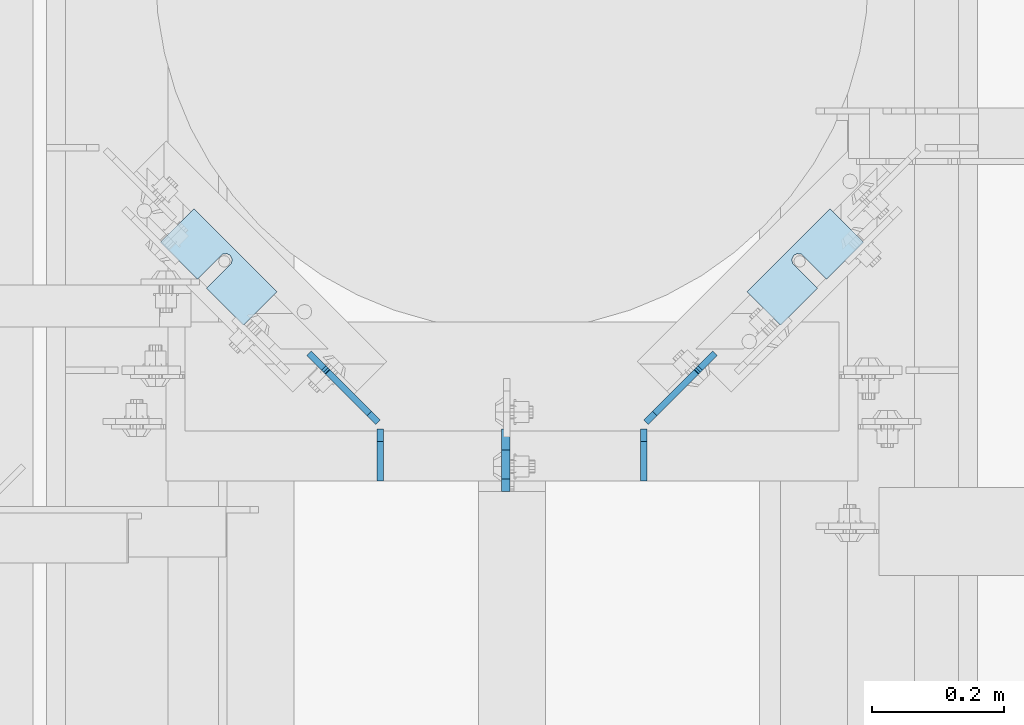
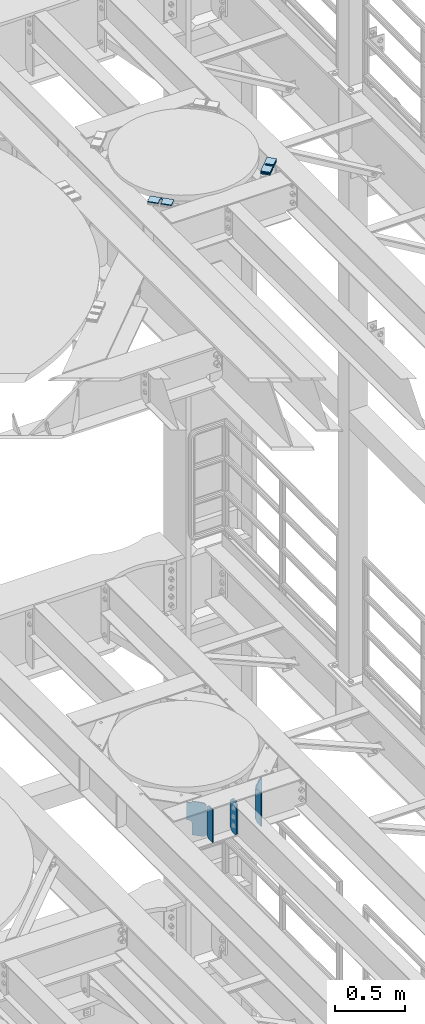
# One storey, part 1791 of 1876: 14 plates, 10 elements without a shape of their own.
"""IFC2X3 building model written with IfcOpenShell, lengths in millimetres."""

from ifc_helpers import new_model, si_unit, frame, origin_with_axes, place, context, subcontext, project, spatial, faceted_brep, material, type_object, element, aggregate, save


model = new_model("IFC2X3")

# Units and contexts
model_context = context("Model", 3, precision=1e-05, world=origin_with_axes())
body_context = subcontext(model_context, "Body", "Model", "MODEL_VIEW")
ifc_project = project(units=[si_unit("LENGTHUNIT", "METRE", prefix="MILLI"), si_unit("AREAUNIT", "SQUARE_METRE"), si_unit("VOLUMEUNIT", "CUBIC_METRE"), si_unit("MASSUNIT", "GRAM", prefix="KILO"), si_unit("TIMEUNIT", "SECOND"), si_unit("PLANEANGLEUNIT", "RADIAN"), si_unit("SOLIDANGLEUNIT", "STERADIAN"), si_unit("THERMODYNAMICTEMPERATUREUNIT", "DEGREE_CELSIUS"), si_unit("LUMINOUSINTENSITYUNIT", "LUMEN")], contexts=[model_context])

# Site, building, storey
site_placement = place(None, origin_with_axes())
site = spatial("IfcSite", under=ifc_project, at=site_placement, CompositionType="ELEMENT")
building_placement = place(site_placement, origin_with_axes())
building = spatial("IfcBuilding", under=site, at=building_placement, Name="Undefined", CompositionType="ELEMENT")
storey_placement = place(building_placement, origin_with_axes())
storey = spatial("IfcBuildingStorey", under=building, at=storey_placement, Name="Undefined", CompositionType="ELEMENT", Elevation=0.0)

# Assembly, plates
assembly_1_placement = place(storey_placement, origin_with_axes())
assembly_1 = element("IfcElementAssembly", 1, at=assembly_1_placement, inside=storey, Name="BEAM", AssemblyPlace="NOTDEFINED", PredefinedType="RIGID_FRAME")
ifc_material = material(Name="STEEL/A36")
plate_type_1 = type_object("IfcPlateType", PredefinedType="NOTDEFINED")
plate_1_placement = place(assembly_1_placement, frame((6099.17499990463, 10791.825, 7853.3625), z_axis=(0.0, 0.0, 1.0), x_axis=(0.0, -1.0, 0.0)))
plate_1 = element("IfcPlate", 2, at=plate_1_placement, type_object=plate_type_1, material=ifc_material, Name="PLATE", context=body_context, shape_type="Brep", body=[
    faceted_brep([(0.0, -6.34999999999991, 31.75), (0.0, -6.35000000000036, 258.762512207031), (0.0, 6.35000000000036, 258.762512207031), (0.0, 6.34999999999991, 31.75), (31.75, -6.35000000000036, 290.512512207031), (31.75, 6.35000000000036, 290.512512207031), (76.2000007629395, -6.35000000000036, 290.512512207031), (76.2000007629395, 6.35000000000036, 290.512512207031), (95.25, -6.35000000000036, 271.462512969971), (95.25, 6.35000000000036, 271.462512969971), (95.25, -6.35000000000036, 19.0499992370605), (95.25, 6.35000000000036, 19.0499992370605), (76.2000007629395, -6.35000000000036, 0.0), (76.2000007629395, 6.35000000000036, 0.0), (31.75, -6.34999999999991, 0.0), (31.75, 6.34999999999991, 0.0)], [[[0, 1, 2, 3]], [[1, 4, 5, 2]], [[4, 6, 7, 5]], [[6, 8, 9, 7]], [[8, 10, 11, 9]], [[10, 12, 13, 11]], [[12, 14, 15, 13]], [[14, 0, 3, 15]], [[5, 7, 9, 11, 13, 15, 3, 2]], [[14, 12, 10, 8, 6, 4, 1, 0]]]),
])
plate_type_2 = type_object("IfcPlateType", PredefinedType="NOTDEFINED")
plate_2_placement = place(assembly_1_placement, frame((6308.27321782047, 10791.825, 7853.3625), z_axis=(0.0, 0.0, 1.0), x_axis=(0.0, -1.0, 0.0)))
plate_2 = element("IfcPlate", 3, at=plate_2_placement, type_object=plate_type_2, material=ifc_material, Name="PLATE", context=body_context, shape_type="Brep", body=[
    faceted_brep([(0.0, -4.76249999999982, 19.0499992370605), (0.0, -4.76250000000073, 269.874988555908), (0.0, 4.76250000000073, 269.874988555908), (0.0, 4.76249999999982, 19.0499992370605), (19.0499992370605, -4.76250000000073, 288.924987792969), (19.0499992370605, 4.76250000000073, 288.924987792969), (79.375, -4.76250000000073, 288.924987792969), (79.375, 4.76250000000073, 288.924987792969), (79.375, -4.76250000000073, 0.0), (79.375, 4.76250000000073, 0.0), (19.0499992370605, -4.76249999999982, 0.0), (19.0499992370605, 4.76249999999982, 0.0)], [[[0, 1, 2, 3]], [[1, 4, 5, 2]], [[4, 6, 7, 5]], [[6, 8, 9, 7]], [[8, 10, 11, 9]], [[10, 0, 3, 11]], [[5, 7, 9, 11, 3, 2]], [[10, 8, 6, 4, 1, 0]]]),
])
plate_3_placement = place(assembly_1_placement, frame((5909.12678217874, 10791.825, 7853.36250000001), z_axis=(0.0, 0.0, 1.0), x_axis=(0.0, -1.0, 0.0)))
plate_3 = element("IfcPlate", 4, at=plate_3_placement, type_object=plate_type_2, material=ifc_material, Name="PLATE", context=body_context, shape_type="Brep", body=[
    faceted_brep([(0.0, -4.76249999999982, 19.0499992370605), (0.0, -4.76250000000073, 269.874988555908), (0.0, 4.76250000000073, 269.874988555908), (0.0, 4.76249999999982, 19.0499992370605), (19.0499992370605, -4.76250000000073, 288.924987792969), (19.0499992370605, 4.76250000000073, 288.924987792969), (79.375, -4.76250000000073, 288.924987792969), (79.375, 4.76250000000073, 288.924987792969), (79.375, -4.76250000000073, 0.0), (79.375, 4.76250000000073, 0.0), (19.0499992370605, -4.76249999999982, 0.0), (19.0499992370605, 4.76249999999982, 0.0)], [[[0, 1, 2, 3]], [[1, 4, 5, 2]], [[4, 6, 7, 5]], [[6, 8, 9, 7]], [[8, 10, 11, 9]], [[10, 0, 3, 11]], [[5, 7, 9, 11, 3, 2]], [[10, 8, 6, 4, 1, 0]]]),
])
plate_type_3 = type_object("IfcPlateType", PredefinedType="NOTDEFINED")
plate_4_placement = place(assembly_1_placement, frame((6311.64310582087, 10801.5430549594, 7870.825), z_axis=(0.500120633849922, 0.499879336849994, 0.707106781319457), x_axis=(0.500120634037941, 0.499879337037901, -0.707106781053638)))
plate_4 = element("IfcPlate", 5, at=plate_4_placement, type_object=plate_type_3, material=ifc_material, Name="PLATE", context=body_context, shape_type="Brep", body=[
    faceted_brep([(0.0, -4.76249999999982, 0.0), (-179.605117797772, -4.76249999999527, 179.605117797992), (-179.605117797772, 4.76250000000437, 179.605117797993), (0.0, 4.76249999999982, 0.0), (-179.605117797761, -4.76249999999891, 206.545883178862), (-179.605117797761, 4.76250000000255, 206.545883178861), (-117.050567626848, -4.76250000000618, 269.100433349755), (-117.050567626846, 4.76249999999163, 269.100433349757), (-115.928035765697, -4.762500000008, 267.977902251546), (-115.928035765697, 4.76249999999163, 267.977902251546), (-111.292837558296, -4.762500000008, 264.880763707778), (-111.292837558296, 4.76249999998981, 264.880763707779), (-105.825249325861, -4.76250000000982, 263.793193709241), (-105.825249325861, 4.76249999998981, 263.793193709242), (-100.357661316782, -4.76250000001164, 264.880764830663), (-100.357661316781, 4.76249999998981, 264.880764830663), (-95.7224637454437, -4.76250000001346, 267.977904326366), (-95.7224637454419, 4.76249999998618, 267.977904326366), (-77.4542999266487, -4.76250000001892, 286.246063232559), (-77.4542999266469, 4.76249999998254, 286.246063232559), (30.3087749481838, -4.76250000002619, 178.483001709037), (30.3087749481838, 4.76249999997526, 178.483001709038), (14.2856747239093, -4.76250000002074, 162.459897647188), (14.2856747239111, 4.7624999999789, 162.459897647189), (10.5002814525251, -4.76250000001892, 156.794654920826), (10.5002814525251, 4.76249999998072, 156.794654920827), (9.17102848077957, -4.76250000001892, 150.112045856642), (9.17102848077957, 4.76249999998072, 150.112045856642), (10.5002825029787, -4.76250000002074, 143.429437001402), (10.5002825029787, 4.76249999998072, 143.429437001403), (14.2856766648929, -4.76250000001892, 137.764194870075), (14.2856766648929, 4.76249999998072, 137.764194870074), (89.4953231811687, -4.76250000002437, 62.5545539855825), (89.4953231811687, 4.76249999997708, 62.5545539855834), (26.9407691955548, -4.76250000000618, -2.22826201934367e-11), (26.9407691955548, 4.76249999999345, -2.22826201934367e-11)], [[[0, 1, 2, 3]], [[1, 4, 5, 2]], [[4, 6, 7, 5]], [[6, 8, 9, 7]], [[8, 10, 11, 9]], [[10, 12, 13, 11]], [[12, 14, 15, 13]], [[14, 16, 17, 15]], [[16, 18, 19, 17]], [[18, 20, 21, 19]], [[20, 22, 23, 21]], [[22, 24, 25, 23]], [[24, 26, 27, 25]], [[26, 28, 29, 27]], [[28, 30, 31, 29]], [[30, 32, 33, 31]], [[32, 34, 35, 33]], [[34, 0, 3, 35]], [[5, 7, 9, 11, 13, 15, 17, 19, 21, 23, 25, 27, 29, 31, 33, 35, 3, 2]], [[34, 32, 30, 28, 26, 24, 22, 20, 18, 16, 14, 12, 10, 8, 6, 4, 1, 0]]]),
])
plate_5_placement = place(assembly_1_placement, frame((5905.75689417819, 10801.5430549604, 7870.825), z_axis=(-0.50012063384991, 0.499879336849982, 0.707106781319474), x_axis=(-0.500120634037935, 0.499879337037929, -0.707106781053622)))
plate_5 = element("IfcPlate", 6, at=plate_5_placement, type_object=plate_type_3, material=ifc_material, Name="PLATE", context=body_context, shape_type="Brep", body=[
    faceted_brep([(0.0, -4.76249999999982, 0.0), (-179.605117797772, -4.76249999999527, 179.605117797992), (-179.605117797772, 4.76250000000437, 179.605117797993), (0.0, 4.76249999999982, 0.0), (-179.605117797761, -4.76249999999891, 206.545883178862), (-179.605117797761, 4.76250000000255, 206.545883178861), (-117.050567626848, -4.76250000000618, 269.100433349755), (-117.050567626846, 4.76249999999163, 269.100433349757), (-115.928035765697, -4.762500000008, 267.977902251546), (-115.928035765697, 4.76249999999163, 267.977902251546), (-111.292837558296, -4.762500000008, 264.880763707778), (-111.292837558296, 4.76249999998981, 264.880763707779), (-105.825249325861, -4.76250000000982, 263.793193709241), (-105.825249325861, 4.76249999998981, 263.793193709242), (-100.357661316782, -4.76250000001164, 264.880764830663), (-100.357661316781, 4.76249999998981, 264.880764830663), (-95.7224637454437, -4.76250000001346, 267.977904326366), (-95.7224637454419, 4.76249999998618, 267.977904326366), (-77.4542999266487, -4.76250000001892, 286.246063232559), (-77.4542999266469, 4.76249999998254, 286.246063232559), (30.3087749481838, -4.76250000002619, 178.483001709037), (30.3087749481838, 4.76249999997526, 178.483001709038), (14.2856747239093, -4.76250000002074, 162.459897647188), (14.2856747239111, 4.7624999999789, 162.459897647189), (10.5002814525251, -4.76250000001892, 156.794654920826), (10.5002814525251, 4.76249999998072, 156.794654920827), (9.17102848077957, -4.76250000001892, 150.112045856642), (9.17102848077957, 4.76249999998072, 150.112045856642), (10.5002825029787, -4.76250000002074, 143.429437001402), (10.5002825029787, 4.76249999998072, 143.429437001403), (14.2856766648929, -4.76250000001892, 137.764194870075), (14.2856766648929, 4.76249999998072, 137.764194870074), (89.4953231811687, -4.76250000002437, 62.5545539855825), (89.4953231811687, 4.76249999997708, 62.5545539855834), (26.9407691955548, -4.76250000000618, -2.22826201934367e-11), (26.9407691955548, 4.76249999999345, -2.22826201934367e-11)], [[[0, 1, 2, 3]], [[1, 4, 5, 2]], [[4, 6, 7, 5]], [[6, 8, 9, 7]], [[8, 10, 11, 9]], [[10, 12, 13, 11]], [[12, 14, 15, 13]], [[14, 16, 17, 15]], [[16, 18, 19, 17]], [[18, 20, 21, 19]], [[20, 22, 23, 21]], [[22, 24, 25, 23]], [[24, 26, 27, 25]], [[26, 28, 29, 27]], [[28, 30, 31, 29]], [[30, 32, 33, 31]], [[32, 34, 35, 33]], [[34, 0, 3, 35]], [[5, 7, 9, 11, 13, 15, 17, 19, 21, 23, 25, 27, 29, 31, 33, 35, 3, 2]], [[34, 32, 30, 28, 26, 24, 22, 20, 18, 16, 14, 12, 10, 8, 6, 4, 1, 0]]]),
])
aggregate(assembly_1, [plate_1, plate_2, plate_4, plate_3, plate_5])

# Assembly, plate
assembly_2_placement = place(storey_placement, origin_with_axes())
assembly_2 = element("IfcElementAssembly", 7, at=assembly_2_placement, inside=storey, Name="SHIM PLATE", AssemblyPlace="NOTDEFINED", PredefinedType="RIGID_FRAME")
plate_type_4 = type_object("IfcPlateType", PredefinedType="NOTDEFINED")
plate_6_placement = place(assembly_2_placement, frame((6464.5722604217, 10999.2121093142, 13335.7925), z_axis=(0.707095463095971, 0.707118099095967, 0.0), x_axis=(0.707118099095967, -0.707095463095971, 0.0)))
plate_6 = element("IfcPlate", 8, at=plate_6_placement, type_object=plate_type_4, material=ifc_material, Name="SHIM PLATE", context=body_context, shape_type="Brep", body=[
    faceted_brep([(71.4045474198501, -0.793499999999767, 79.3704623494177), (71.4045474198501, 0.793499999999767, 79.3704623494177), (23.7781246776649, 0.793499999999767, 79.3704112277637), (23.7781246776649, -0.793499999999767, 79.3704112277637), (17.7435939503794, 0.793499999999767, 79.5232321855556), (17.7435939503794, -0.793499999999767, 79.5232321855556), (12.9144746082529, 0.793499999999767, 83.1451821745986), (12.9144746082529, -0.793499999999767, 83.1451821745986), (11.0782662795154, 0.793499999999767, 88.8955955786168), (11.0782662795154, -0.793499999999767, 88.8955955786168), (12.9146418967375, 0.793499999999767, 94.6459555617994), (12.9146418967375, -0.793499999999767, 94.6459555617994), (17.7438666054786, 0.793499999999767, 98.267765062069), (17.7438666054786, -0.793499999999767, 98.267765062069), (23.7784017760332, 0.793499999999767, 98.4204104651026), (23.7784017760332, -0.793499999999767, 98.4204104651026), (71.4046756165244, -0.793499999999767, 98.4204615866147), (71.4045269830331, 0.793499999999767, 98.4204615864555), (71.4046325683794, -0.793499999999767, -1.18234311230481e-11), (9.09494701772928e-13, -0.793499999999767, 0.0), (9.09494701772928e-13, 0.793499999999767, 0.0), (71.4046325683794, 0.793499999999767, -1.18234311230481e-11), (0.00273432340327417, -0.793499999999767, 177.792755126891), (0.00273432340327417, 0.793499999999767, 177.792755126891), (71.4044418336562, -0.793499999999767, 177.791717529223), (71.4044418336562, 0.793499999999767, 177.791717529223)], [[[0, 1, 2, 3]], [[3, 2, 4, 5]], [[5, 4, 6, 7]], [[7, 6, 8, 9]], [[9, 8, 10, 11]], [[11, 10, 12, 13]], [[13, 12, 14, 15]], [[16, 15, 14, 17]], [[18, 19, 20, 21]], [[19, 22, 23, 20]], [[22, 24, 25, 23]], [[25, 24, 16, 17]], [[12, 10, 8, 6, 4, 2, 1, 21, 20, 23, 25, 17, 14]], [[18, 21, 1, 0]], [[24, 22, 19, 18, 0, 3, 5, 7, 9, 11, 13, 15, 16]]]),
])
aggregate(assembly_2, [plate_6])

assembly_3_placement = place(storey_placement, origin_with_axes())
assembly_3 = element("IfcElementAssembly", 9, at=assembly_3_placement, inside=storey, Name="SHIM PLATE", AssemblyPlace="NOTDEFINED", PredefinedType="RIGID_FRAME")
plate_7_placement = place(assembly_3_placement, frame((5752.8277395783, 10999.2121093142, 13335.7925), z_axis=(-0.707095463095965, 0.707118099095973, 0.0), x_axis=(-0.707118099095974, -0.707095463095965, 0.0)))
plate_7 = element("IfcPlate", 10, at=plate_7_placement, type_object=plate_type_4, material=ifc_material, Name="SHIM PLATE", context=body_context, shape_type="Brep", body=[
    faceted_brep([(71.4045474198501, -0.793499999999767, 79.3704623494177), (71.4045474198501, 0.793499999999767, 79.3704623494177), (23.7781246776649, 0.793499999999767, 79.3704112277637), (23.7781246776649, -0.793499999999767, 79.3704112277637), (17.7435939503794, 0.793499999999767, 79.5232321855556), (17.7435939503794, -0.793499999999767, 79.5232321855556), (12.9144746082529, 0.793499999999767, 83.1451821745986), (12.9144746082529, -0.793499999999767, 83.1451821745986), (11.0782662795154, 0.793499999999767, 88.8955955786168), (11.0782662795154, -0.793499999999767, 88.8955955786168), (12.9146418967375, 0.793499999999767, 94.6459555617994), (12.9146418967375, -0.793499999999767, 94.6459555617994), (17.7438666054786, 0.793499999999767, 98.267765062069), (17.7438666054786, -0.793499999999767, 98.267765062069), (23.7784017760332, 0.793499999999767, 98.4204104651026), (23.7784017760332, -0.793499999999767, 98.4204104651026), (71.4046756165244, -0.793499999999767, 98.4204615866147), (71.4045269830331, 0.793499999999767, 98.4204615864555), (71.4046325683794, -0.793499999999767, -1.18234311230481e-11), (9.09494701772928e-13, -0.793499999999767, 0.0), (9.09494701772928e-13, 0.793499999999767, 0.0), (71.4046325683794, 0.793499999999767, -1.18234311230481e-11), (0.00273432340327417, -0.793499999999767, 177.792755126891), (0.00273432340327417, 0.793499999999767, 177.792755126891), (71.4044418336562, -0.793499999999767, 177.791717529223), (71.4044418336562, 0.793499999999767, 177.791717529223)], [[[0, 1, 2, 3]], [[3, 2, 4, 5]], [[5, 4, 6, 7]], [[7, 6, 8, 9]], [[9, 8, 10, 11]], [[11, 10, 12, 13]], [[13, 12, 14, 15]], [[16, 15, 14, 17]], [[18, 19, 20, 21]], [[19, 22, 23, 20]], [[22, 24, 25, 23]], [[25, 24, 16, 17]], [[12, 10, 8, 6, 4, 2, 1, 21, 20, 23, 25, 17, 14]], [[18, 21, 1, 0]], [[24, 22, 19, 18, 0, 3, 5, 7, 9, 11, 13, 15, 16]]]),
])
aggregate(assembly_3, [plate_7])

assembly_4_placement = place(storey_placement, origin_with_axes())
assembly_4 = element("IfcElementAssembly", 11, at=assembly_4_placement, inside=storey, Name="SHIM PLATE", AssemblyPlace="NOTDEFINED", PredefinedType="RIGID_FRAME")
plate_type_5 = type_object("IfcPlateType", PredefinedType="NOTDEFINED")
plate_8_placement = place(assembly_4_placement, frame((6464.5722604217, 10999.2121093142, 13333.4115), z_axis=(0.707095463095971, 0.707118099095967, 0.0), x_axis=(0.707118099095967, -0.707095463095971, 0.0)))
plate_8 = element("IfcPlate", 12, at=plate_8_placement, type_object=plate_type_5, material=ifc_material, Name="SHIM PLATE", context=body_context, shape_type="Brep", body=[
    faceted_brep([(71.404547419852, -1.58749999999964, 79.3704623494154), (71.404547419852, 1.58749999999964, 79.3704623494154), (23.7781246776667, 1.58749999999964, 79.3704112277624), (23.7781246776667, -1.58749999999964, 79.3704112277624), (17.7435939503812, 1.58749999999964, 79.5232321855533), (17.7435939503812, -1.58749999999964, 79.5232321855533), (12.9144746082547, 1.58749999999964, 83.1451821745973), (12.9144746082547, -1.58749999999964, 83.1451821745973), (11.0782662795191, 1.58749999999964, 88.8955955786155), (11.0782662795191, -1.58749999999964, 88.8955955786155), (12.9146418967412, 1.58749999999964, 94.6459555617989), (12.9146418967412, -1.58749999999964, 94.6459555617989), (17.7438666054804, 1.58749999999964, 98.2677650620694), (17.7438666054804, -1.58749999999964, 98.2677650620694), (23.778401776035, 1.58749999999964, 98.420410465103), (23.778401776035, -1.58749999999964, 98.420410465103), (71.404675616528, -1.58749999999964, 98.4204615866124), (71.4045269830367, 1.58749999999964, 98.4204615864542), (71.4046325683794, -1.58749999999964, -1.13686837721616e-11), (9.09494701772928e-13, -1.58750000000146, 4.54747350886464e-13), (9.09494701772928e-13, 1.58750000000146, 4.54747350886464e-13), (71.4046325683794, 1.58749999999964, -1.13686837721616e-11), (0.00273432340873114, -1.58749999999964, 177.792755126889), (0.00273432340873114, 1.58749999999964, 177.792755126889), (71.404441833658, -1.58749999999964, 177.791717529222), (71.404441833658, 1.58749999999964, 177.791717529222)], [[[0, 1, 2, 3]], [[3, 2, 4, 5]], [[5, 4, 6, 7]], [[7, 6, 8, 9]], [[9, 8, 10, 11]], [[11, 10, 12, 13]], [[13, 12, 14, 15]], [[16, 15, 14, 17]], [[18, 19, 20, 21]], [[19, 22, 23, 20]], [[22, 24, 25, 23]], [[25, 24, 16, 17]], [[12, 10, 8, 6, 4, 2, 1, 21, 20, 23, 25, 17, 14]], [[18, 21, 1, 0]], [[24, 22, 19, 18, 0, 3, 5, 7, 9, 11, 13, 15, 16]]]),
])
aggregate(assembly_4, [plate_8])

assembly_5_placement = place(storey_placement, origin_with_axes())
assembly_5 = element("IfcElementAssembly", 13, at=assembly_5_placement, inside=storey, Name="SHIM PLATE", AssemblyPlace="NOTDEFINED", PredefinedType="RIGID_FRAME")
plate_9_placement = place(assembly_5_placement, frame((6464.5722604217, 10999.2121093142, 13330.2365), z_axis=(0.707095463095971, 0.707118099095967, 0.0), x_axis=(0.707118099095967, -0.707095463095971, 0.0)))
plate_9 = element("IfcPlate", 14, at=plate_9_placement, type_object=plate_type_5, material=ifc_material, Name="SHIM PLATE", context=body_context, shape_type="Brep", body=[
    faceted_brep([(71.404547419852, -1.58749999999964, 79.3704623494154), (71.404547419852, 1.58749999999964, 79.3704623494154), (23.7781246776667, 1.58749999999964, 79.3704112277624), (23.7781246776667, -1.58749999999964, 79.3704112277624), (17.7435939503812, 1.58749999999964, 79.5232321855533), (17.7435939503812, -1.58749999999964, 79.5232321855533), (12.9144746082547, 1.58749999999964, 83.1451821745973), (12.9144746082547, -1.58749999999964, 83.1451821745973), (11.0782662795191, 1.58749999999964, 88.8955955786155), (11.0782662795191, -1.58749999999964, 88.8955955786155), (12.9146418967412, 1.58749999999964, 94.6459555617989), (12.9146418967412, -1.58749999999964, 94.6459555617989), (17.7438666054804, 1.58749999999964, 98.2677650620694), (17.7438666054804, -1.58749999999964, 98.2677650620694), (23.778401776035, 1.58749999999964, 98.420410465103), (23.778401776035, -1.58749999999964, 98.420410465103), (71.404675616528, -1.58749999999964, 98.4204615866124), (71.4045269830367, 1.58749999999964, 98.4204615864542), (71.4046325683794, -1.58749999999964, -1.13686837721616e-11), (9.09494701772928e-13, -1.58750000000146, 4.54747350886464e-13), (9.09494701772928e-13, 1.58750000000146, 4.54747350886464e-13), (71.4046325683794, 1.58749999999964, -1.13686837721616e-11), (0.00273432340873114, -1.58749999999964, 177.792755126889), (0.00273432340873114, 1.58749999999964, 177.792755126889), (71.404441833658, -1.58749999999964, 177.791717529222), (71.404441833658, 1.58749999999964, 177.791717529222)], [[[0, 1, 2, 3]], [[3, 2, 4, 5]], [[5, 4, 6, 7]], [[7, 6, 8, 9]], [[9, 8, 10, 11]], [[11, 10, 12, 13]], [[13, 12, 14, 15]], [[16, 15, 14, 17]], [[18, 19, 20, 21]], [[19, 22, 23, 20]], [[22, 24, 25, 23]], [[25, 24, 16, 17]], [[12, 10, 8, 6, 4, 2, 1, 21, 20, 23, 25, 17, 14]], [[18, 21, 1, 0]], [[24, 22, 19, 18, 0, 3, 5, 7, 9, 11, 13, 15, 16]]]),
])
aggregate(assembly_5, [plate_9])

assembly_6_placement = place(storey_placement, origin_with_axes())
assembly_6 = element("IfcElementAssembly", 15, at=assembly_6_placement, inside=storey, Name="SHIM PLATE", AssemblyPlace="NOTDEFINED", PredefinedType="RIGID_FRAME")
plate_10_placement = place(assembly_6_placement, frame((5752.8277395783, 10999.2121093142, 13333.4115), z_axis=(-0.707095463095965, 0.707118099095973, 0.0), x_axis=(-0.707118099095974, -0.707095463095965, 0.0)))
plate_10 = element("IfcPlate", 16, at=plate_10_placement, type_object=plate_type_5, material=ifc_material, Name="SHIM PLATE", context=body_context, shape_type="Brep", body=[
    faceted_brep([(71.404547419852, -1.58749999999964, 79.3704623494154), (71.404547419852, 1.58749999999964, 79.3704623494154), (23.7781246776667, 1.58749999999964, 79.3704112277624), (23.7781246776667, -1.58749999999964, 79.3704112277624), (17.7435939503812, 1.58749999999964, 79.5232321855533), (17.7435939503812, -1.58749999999964, 79.5232321855533), (12.9144746082547, 1.58749999999964, 83.1451821745973), (12.9144746082547, -1.58749999999964, 83.1451821745973), (11.0782662795191, 1.58749999999964, 88.8955955786155), (11.0782662795191, -1.58749999999964, 88.8955955786155), (12.9146418967412, 1.58749999999964, 94.6459555617989), (12.9146418967412, -1.58749999999964, 94.6459555617989), (17.7438666054804, 1.58749999999964, 98.2677650620694), (17.7438666054804, -1.58749999999964, 98.2677650620694), (23.778401776035, 1.58749999999964, 98.420410465103), (23.778401776035, -1.58749999999964, 98.420410465103), (71.404675616528, -1.58749999999964, 98.4204615866124), (71.4045269830367, 1.58749999999964, 98.4204615864542), (71.4046325683794, -1.58749999999964, -1.13686837721616e-11), (9.09494701772928e-13, -1.58750000000146, 4.54747350886464e-13), (9.09494701772928e-13, 1.58750000000146, 4.54747350886464e-13), (71.4046325683794, 1.58749999999964, -1.13686837721616e-11), (0.00273432340873114, -1.58749999999964, 177.792755126889), (0.00273432340873114, 1.58749999999964, 177.792755126889), (71.404441833658, -1.58749999999964, 177.791717529222), (71.404441833658, 1.58749999999964, 177.791717529222)], [[[0, 1, 2, 3]], [[3, 2, 4, 5]], [[5, 4, 6, 7]], [[7, 6, 8, 9]], [[9, 8, 10, 11]], [[11, 10, 12, 13]], [[13, 12, 14, 15]], [[16, 15, 14, 17]], [[18, 19, 20, 21]], [[19, 22, 23, 20]], [[22, 24, 25, 23]], [[25, 24, 16, 17]], [[12, 10, 8, 6, 4, 2, 1, 21, 20, 23, 25, 17, 14]], [[18, 21, 1, 0]], [[24, 22, 19, 18, 0, 3, 5, 7, 9, 11, 13, 15, 16]]]),
])
aggregate(assembly_6, [plate_10])

assembly_7_placement = place(storey_placement, origin_with_axes())
assembly_7 = element("IfcElementAssembly", 17, at=assembly_7_placement, inside=storey, Name="SHIM PLATE", AssemblyPlace="NOTDEFINED", PredefinedType="RIGID_FRAME")
plate_11_placement = place(assembly_7_placement, frame((5752.8277395783, 10999.2121093142, 13330.2365), z_axis=(-0.707095463095965, 0.707118099095973, 0.0), x_axis=(-0.707118099095974, -0.707095463095965, 0.0)))
plate_11 = element("IfcPlate", 18, at=plate_11_placement, type_object=plate_type_5, material=ifc_material, Name="SHIM PLATE", context=body_context, shape_type="Brep", body=[
    faceted_brep([(71.404547419852, -1.58749999999964, 79.3704623494154), (71.404547419852, 1.58749999999964, 79.3704623494154), (23.7781246776667, 1.58749999999964, 79.3704112277624), (23.7781246776667, -1.58749999999964, 79.3704112277624), (17.7435939503812, 1.58749999999964, 79.5232321855533), (17.7435939503812, -1.58749999999964, 79.5232321855533), (12.9144746082547, 1.58749999999964, 83.1451821745973), (12.9144746082547, -1.58749999999964, 83.1451821745973), (11.0782662795191, 1.58749999999964, 88.8955955786155), (11.0782662795191, -1.58749999999964, 88.8955955786155), (12.9146418967412, 1.58749999999964, 94.6459555617989), (12.9146418967412, -1.58749999999964, 94.6459555617989), (17.7438666054804, 1.58749999999964, 98.2677650620694), (17.7438666054804, -1.58749999999964, 98.2677650620694), (23.778401776035, 1.58749999999964, 98.420410465103), (23.778401776035, -1.58749999999964, 98.420410465103), (71.404675616528, -1.58749999999964, 98.4204615866124), (71.4045269830367, 1.58749999999964, 98.4204615864542), (71.4046325683794, -1.58749999999964, -1.13686837721616e-11), (9.09494701772928e-13, -1.58750000000146, 4.54747350886464e-13), (9.09494701772928e-13, 1.58750000000146, 4.54747350886464e-13), (71.4046325683794, 1.58749999999964, -1.13686837721616e-11), (0.00273432340873114, -1.58749999999964, 177.792755126889), (0.00273432340873114, 1.58749999999964, 177.792755126889), (71.404441833658, -1.58749999999964, 177.791717529222), (71.404441833658, 1.58749999999964, 177.791717529222)], [[[0, 1, 2, 3]], [[3, 2, 4, 5]], [[5, 4, 6, 7]], [[7, 6, 8, 9]], [[9, 8, 10, 11]], [[11, 10, 12, 13]], [[13, 12, 14, 15]], [[16, 15, 14, 17]], [[18, 19, 20, 21]], [[19, 22, 23, 20]], [[22, 24, 25, 23]], [[25, 24, 16, 17]], [[12, 10, 8, 6, 4, 2, 1, 21, 20, 23, 25, 17, 14]], [[18, 21, 1, 0]], [[24, 22, 19, 18, 0, 3, 5, 7, 9, 11, 13, 15, 16]]]),
])
aggregate(assembly_7, [plate_11])

assembly_8_placement = place(storey_placement, origin_with_axes())
assembly_8 = element("IfcElementAssembly", 19, at=assembly_8_placement, inside=storey, Name="SHIM PLATE", AssemblyPlace="NOTDEFINED", PredefinedType="RIGID_FRAME")
plate_type_6 = type_object("IfcPlateType", PredefinedType="NOTDEFINED")
plate_12_placement = place(assembly_8_placement, frame((6464.57226042169, 10999.2121093142, 13326.268), z_axis=(0.707095463095971, 0.707118099095967, 0.0), x_axis=(0.707118099095967, -0.707095463095971, 0.0)))
plate_12 = element("IfcPlate", 20, at=plate_12_placement, type_object=plate_type_6, material=ifc_material, Name="SHIM PLATE", context=body_context, shape_type="Brep", body=[
    faceted_brep([(71.4045474198501, -2.3809999999994, 79.3704623494173), (71.4045474198501, 2.3809999999994, 79.3704623494173), (23.7781246776667, 2.3809999999994, 79.3704112277633), (23.7781246776667, -2.3809999999994, 79.3704112277633), (17.7435939503794, 2.3809999999994, 79.5232321855551), (17.7435939503794, -2.3809999999994, 79.5232321855551), (12.9144746082547, 2.3809999999994, 83.1451821745982), (12.9144746082547, -2.3809999999994, 83.1451821745982), (11.0782662795191, 2.3809999999994, 88.8955955786164), (11.0782662795191, -2.3809999999994, 88.8955955786164), (12.9146418967412, 2.3809999999994, 94.6459555618007), (12.9146418967412, -2.3809999999994, 94.6459555618007), (17.7438666054804, 2.3809999999994, 98.2677650620712), (17.7438666054804, -2.3809999999994, 98.2677650620712), (23.778401776035, 2.3809999999994, 98.4204104651049), (23.778401776035, -2.3809999999994, 98.4204104651049), (71.4046756165262, -2.3809999999994, 98.4204615866142), (71.4045269830367, 2.3809999999994, 98.4204615864551), (71.4046325683794, -2.3809999999994, -9.54969436861575e-12), (0.0, -2.38100000000122, 4.54747350886464e-13), (0.0, 2.38100000000122, 4.54747350886464e-13), (71.4046325683794, 2.3809999999994, -9.54969436861575e-12), (0.00273432340873114, -2.3809999999994, 177.792755126891), (0.00273432340873114, 2.3809999999994, 177.792755126891), (71.404441833658, -2.3809999999994, 177.791717529224), (71.404441833658, 2.3809999999994, 177.791717529224)], [[[0, 1, 2, 3]], [[3, 2, 4, 5]], [[5, 4, 6, 7]], [[7, 6, 8, 9]], [[9, 8, 10, 11]], [[11, 10, 12, 13]], [[13, 12, 14, 15]], [[16, 15, 14, 17]], [[18, 19, 20, 21]], [[19, 22, 23, 20]], [[22, 24, 25, 23]], [[25, 24, 16, 17]], [[12, 10, 8, 6, 4, 2, 1, 21, 20, 23, 25, 17, 14]], [[18, 21, 1, 0]], [[24, 22, 19, 18, 0, 3, 5, 7, 9, 11, 13, 15, 16]]]),
])
aggregate(assembly_8, [plate_12])

assembly_9_placement = place(storey_placement, origin_with_axes())
assembly_9 = element("IfcElementAssembly", 21, at=assembly_9_placement, inside=storey, Name="SHIM PLATE", AssemblyPlace="NOTDEFINED", PredefinedType="RIGID_FRAME")
plate_13_placement = place(assembly_9_placement, frame((6464.57226042169, 10999.2121093142, 13321.506), z_axis=(0.707095463095971, 0.707118099095967, 0.0), x_axis=(0.707118099095967, -0.707095463095971, 0.0)))
plate_13 = element("IfcPlate", 22, at=plate_13_placement, type_object=plate_type_6, material=ifc_material, Name="SHIM PLATE", context=body_context, shape_type="Brep", body=[
    faceted_brep([(71.4045474198501, -2.3809999999994, 79.3704623494173), (71.4045474198501, 2.3809999999994, 79.3704623494173), (23.7781246776667, 2.3809999999994, 79.3704112277633), (23.7781246776667, -2.3809999999994, 79.3704112277633), (17.7435939503794, 2.3809999999994, 79.5232321855551), (17.7435939503794, -2.3809999999994, 79.5232321855551), (12.9144746082547, 2.3809999999994, 83.1451821745982), (12.9144746082547, -2.3809999999994, 83.1451821745982), (11.0782662795191, 2.3809999999994, 88.8955955786164), (11.0782662795191, -2.3809999999994, 88.8955955786164), (12.9146418967412, 2.3809999999994, 94.6459555618007), (12.9146418967412, -2.3809999999994, 94.6459555618007), (17.7438666054804, 2.3809999999994, 98.2677650620712), (17.7438666054804, -2.3809999999994, 98.2677650620712), (23.778401776035, 2.3809999999994, 98.4204104651049), (23.778401776035, -2.3809999999994, 98.4204104651049), (71.4046756165262, -2.3809999999994, 98.4204615866142), (71.4045269830367, 2.3809999999994, 98.4204615864551), (71.4046325683794, -2.3809999999994, -9.54969436861575e-12), (0.0, -2.38100000000122, 4.54747350886464e-13), (0.0, 2.38100000000122, 4.54747350886464e-13), (71.4046325683794, 2.3809999999994, -9.54969436861575e-12), (0.00273432340873114, -2.3809999999994, 177.792755126891), (0.00273432340873114, 2.3809999999994, 177.792755126891), (71.404441833658, -2.3809999999994, 177.791717529224), (71.404441833658, 2.3809999999994, 177.791717529224)], [[[0, 1, 2, 3]], [[3, 2, 4, 5]], [[5, 4, 6, 7]], [[7, 6, 8, 9]], [[9, 8, 10, 11]], [[11, 10, 12, 13]], [[13, 12, 14, 15]], [[16, 15, 14, 17]], [[18, 19, 20, 21]], [[19, 22, 23, 20]], [[22, 24, 25, 23]], [[25, 24, 16, 17]], [[12, 10, 8, 6, 4, 2, 1, 21, 20, 23, 25, 17, 14]], [[18, 21, 1, 0]], [[24, 22, 19, 18, 0, 3, 5, 7, 9, 11, 13, 15, 16]]]),
])
aggregate(assembly_9, [plate_13])

assembly_10_placement = place(storey_placement, origin_with_axes())
assembly_10 = element("IfcElementAssembly", 23, at=assembly_10_placement, inside=storey, Name="SHIM PLATE", AssemblyPlace="NOTDEFINED", PredefinedType="RIGID_FRAME")
plate_type_7 = type_object("IfcPlateType", PredefinedType="NOTDEFINED")
plate_14_placement = place(assembly_10_placement, frame((6464.57226042169, 10999.2121093142, 13314.3625), z_axis=(0.707095463095971, 0.707118099095967, 0.0), x_axis=(0.707118099095967, -0.707095463095971, 0.0)))
plate_14 = element("IfcPlate", 24, at=plate_14_placement, type_object=plate_type_7, material=ifc_material, Name="SHIM PLATE", context=body_context, shape_type="Brep", body=[
    faceted_brep([(71.4045474198483, -4.76250000000073, 79.3704623494177), (71.4045474198483, 4.76250000000073, 79.3704623494177), (23.7781246776667, 4.76250000000073, 79.370411227761), (23.7781246776667, -4.76250000000073, 79.370411227761), (17.7435939503775, 4.76250000000073, 79.5232321855528), (17.7435939503775, -4.76250000000073, 79.5232321855528), (12.9144746082511, 4.76250000000073, 83.1451821745959), (12.9144746082511, -4.76250000000073, 83.1451821745959), (11.0782662795173, 4.76250000000073, 88.8955955786141), (11.0782662795173, -4.76250000000073, 88.8955955786141), (12.9146418967375, 4.76250000000073, 94.6459555617985), (12.9146418967375, -4.76250000000073, 94.6459555617985), (17.7438666054786, 4.76250000000073, 98.2677650620672), (17.7438666054786, -4.76250000000073, 98.2677650620672), (23.7784017760332, 4.76250000000073, 98.4204104651026), (23.7784017760332, -4.76250000000073, 98.4204104651026), (71.4046756165244, -4.76250000000073, 98.4204615866129), (71.4045269830349, 4.76250000000073, 98.4204615864537), (71.4046325683794, -4.76250000000073, -1.18234311230481e-11), (0.0, -4.76249999999982, 0.0), (0.0, 4.76249999999982, 0.0), (71.4046325683794, 4.76250000000073, -1.18234311230481e-11), (0.00273432340145519, -4.76250000000073, 177.792755126889), (0.00273432340145519, 4.76250000000073, 177.792755126889), (71.4044418336543, -4.76250000000073, 177.791717529221), (71.4044418336543, 4.76250000000073, 177.791717529221)], [[[0, 1, 2, 3]], [[3, 2, 4, 5]], [[5, 4, 6, 7]], [[7, 6, 8, 9]], [[9, 8, 10, 11]], [[11, 10, 12, 13]], [[13, 12, 14, 15]], [[16, 15, 14, 17]], [[18, 19, 20, 21]], [[19, 22, 23, 20]], [[22, 24, 25, 23]], [[25, 24, 16, 17]], [[12, 10, 8, 6, 4, 2, 1, 21, 20, 23, 25, 17, 14]], [[18, 21, 1, 0]], [[24, 22, 19, 18, 0, 3, 5, 7, 9, 11, 13, 15, 16]]]),
])
aggregate(assembly_10, [plate_14])

save(model, "model.ifc")
